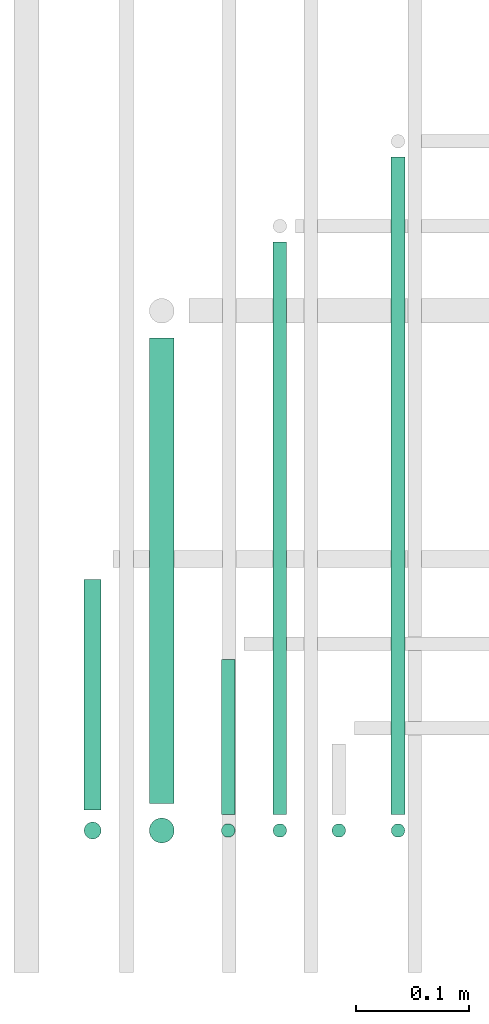
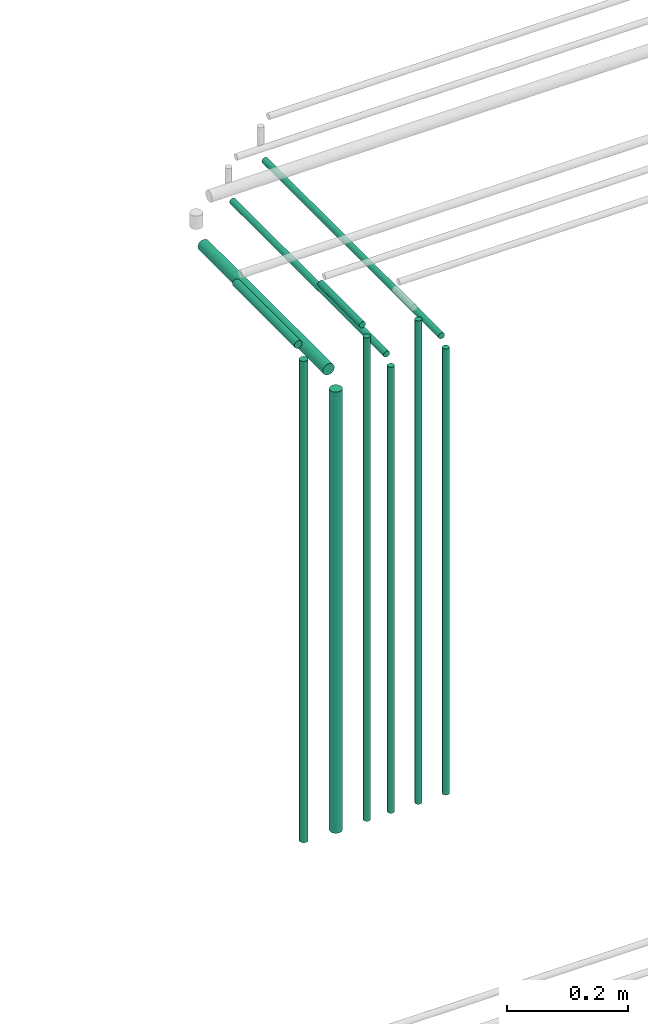
# One storey, part 125 of 331: 11 flow segments.
"""IFC2X3 building model written with IfcOpenShell, lengths in millimetres."""

from ifc_helpers import new_model, entity, si_unit, converted_unit, derived_unit, direction, frame, frame_2d, origin, origin_2d_with_axis, place, context, subcontext, project, spatial, circle, extrude, type_object, element, save


model = new_model("IFC2X3")

# Units and contexts
model_context = context("Model", 3, precision=0.01, world=origin(), true_north=direction((6.12303176911189e-17, 1.0)))
body_context = subcontext(model_context, "Body", "Model", "MODEL_VIEW")
ifc_project = project(units=[si_unit("LENGTHUNIT", "METRE", prefix="MILLI"), si_unit("AREAUNIT", "SQUARE_METRE"), si_unit("VOLUMEUNIT", "CUBIC_METRE"), converted_unit("PLANEANGLEUNIT", "DEGREE", entity("IfcRatioMeasure", 0.0174532925199433), si_unit("PLANEANGLEUNIT", "RADIAN"), dimensions=[0, 0, 0, 0, 0, 0, 0]), si_unit("MASSUNIT", "GRAM", prefix="KILO"), derived_unit("MASSDENSITYUNIT", [(si_unit("MASSUNIT", "GRAM", prefix="KILO"), 1), (si_unit("LENGTHUNIT", "METRE"), -3)]), derived_unit("MOMENTOFINERTIAUNIT", [(si_unit("LENGTHUNIT", "METRE"), 4)]), si_unit("TIMEUNIT", "SECOND"), si_unit("FREQUENCYUNIT", "HERTZ"), si_unit("THERMODYNAMICTEMPERATUREUNIT", "DEGREE_CELSIUS"), derived_unit("THERMALTRANSMITTANCEUNIT", [(si_unit("MASSUNIT", "GRAM", prefix="KILO"), 1), (si_unit("THERMODYNAMICTEMPERATUREUNIT", "KELVIN"), -1), (si_unit("TIMEUNIT", "SECOND"), -3)]), derived_unit("VOLUMETRICFLOWRATEUNIT", [(si_unit("LENGTHUNIT", "METRE"), 3), (si_unit("TIMEUNIT", "SECOND"), -1)]), derived_unit("MASSFLOWRATEUNIT", [(si_unit("MASSUNIT", "GRAM", prefix="KILO"), 1), (si_unit("TIMEUNIT", "SECOND"), -1)]), derived_unit("ROTATIONALFREQUENCYUNIT", [(si_unit("TIMEUNIT", "SECOND"), -1)]), si_unit("ELECTRICCURRENTUNIT", "AMPERE"), si_unit("ELECTRICVOLTAGEUNIT", "VOLT"), si_unit("POWERUNIT", "WATT"), si_unit("FORCEUNIT", "NEWTON", prefix="KILO"), si_unit("ILLUMINANCEUNIT", "LUX"), si_unit("LUMINOUSFLUXUNIT", "LUMEN"), si_unit("LUMINOUSINTENSITYUNIT", "CANDELA"), derived_unit("USERDEFINED", [(si_unit("MASSUNIT", "GRAM", prefix="KILO"), -1), (si_unit("LENGTHUNIT", "METRE"), -2), (si_unit("TIMEUNIT", "SECOND"), 3), (si_unit("LUMINOUSFLUXUNIT", "LUMEN"), 1)]), derived_unit("LINEARVELOCITYUNIT", [(si_unit("LENGTHUNIT", "METRE"), 1), (si_unit("TIMEUNIT", "SECOND"), -1)]), si_unit("PRESSUREUNIT", "PASCAL"), derived_unit("USERDEFINED", [(si_unit("LENGTHUNIT", "METRE"), -2), (si_unit("MASSUNIT", "GRAM", prefix="KILO"), 1), (si_unit("TIMEUNIT", "SECOND"), -2)]), derived_unit("LINEARFORCEUNIT", [(si_unit("MASSUNIT", "GRAM", prefix="KILO"), 1), (si_unit("LENGTHUNIT", "METRE"), 1), (si_unit("TIMEUNIT", "SECOND"), -2), (si_unit("LENGTHUNIT", "METRE"), -1)]), derived_unit("PLANARFORCEUNIT", [(si_unit("MASSUNIT", "GRAM", prefix="KILO"), 1), (si_unit("LENGTHUNIT", "METRE"), 1), (si_unit("TIMEUNIT", "SECOND"), -2), (si_unit("LENGTHUNIT", "METRE"), -2)])], contexts=[model_context])

# Site, building, storey
site_placement = place(None, frame((0.0, -0.00077364408347762, 0.0)))
site = spatial("IfcSite", under=ifc_project, at=site_placement, CompositionType="ELEMENT")
building_placement = place(site_placement, origin())
building = spatial("IfcBuilding", under=site, at=building_placement, CompositionType="ELEMENT")
storey_placement = place(building_placement, origin())
storey = spatial("IfcBuildingStorey", under=building, at=storey_placement, CompositionType="ELEMENT", Elevation=0.0)

# Flow segments
pipe_segment_type = type_object("IfcPipeSegmentType", PredefinedType="NOTDEFINED")
flow_segment_1_placement = place(storey_placement, frame((18973.7737980249, 8079.62056382735, 14467.404727873)))
element("IfcFlowSegment", 1, at=flow_segment_1_placement, inside=storey, type_object=pipe_segment_type, context=body_context, shape_type="SweptSolid", body=[
    extrude(circle(Radius=6.0, at=frame_2d((2.16573425859679e-12, 0.0), x_axis=(1.0, 0.0))), frame((7.59527223591887, 0.0, 7.5952722359167), z_axis=(0.0, 1.0, 0.0), x_axis=(-1.0, 0.0, 0.0)), (0.0, 0.0, 1.0), 582.000000000014),
])
flow_segment_2_placement = place(storey_placement, frame((18973.7737980249, 8058.02529159144, 13564.0)))
element("IfcFlowSegment", 2, at=flow_segment_2_placement, inside=storey, type_object=pipe_segment_type, context=body_context, shape_type="SweptSolid", body=[
    extrude(circle(Radius=6.0, at=origin_2d_with_axis()), frame((7.5952722359167, 7.59527223591562, 0.0)), (0.0, 0.0, 1.0), 897.000000108925),
])
flow_segment_3_placement = place(storey_placement, frame((18921.4061109664, 8058.02529159144, 13564.0)))
element("IfcFlowSegment", 3, at=flow_segment_3_placement, inside=storey, type_object=pipe_segment_type, context=body_context, shape_type="SweptSolid", body=[
    extrude(circle(Radius=6.0, at=origin_2d_with_axis()), frame((7.5952722359167, 7.59527223591562, 0.0)), (0.0, 0.0, 1.0), 972.000000000011),
])
flow_segment_4_placement = place(storey_placement, frame((18869.2157915365, 8079.62056382735, 14467.404727873)))
element("IfcFlowSegment", 4, at=flow_segment_4_placement, inside=storey, type_object=pipe_segment_type, context=body_context, shape_type="SweptSolid", body=[
    extrude(circle(Radius=6.0, at=frame_2d((6.49720277579036e-12, 0.0), x_axis=(1.0, 0.0))), frame((7.5952722359232, 0.0, 7.5952722359167), z_axis=(0.0, 1.0, 0.0), x_axis=(-1.0, 0.0, 0.0)), (0.0, 0.0, 1.0), 507.000000000026),
])
flow_segment_5_placement = place(storey_placement, frame((18869.2157915365, 8058.02529159143, 13564.0)))
element("IfcFlowSegment", 5, at=flow_segment_5_placement, inside=storey, type_object=pipe_segment_type, context=body_context, shape_type="SweptSolid", body=[
    extrude(circle(Radius=6.0, at=frame_2d((0.0, 1.08286712929839e-12), x_axis=(1.0, 0.0))), frame((7.5952722359167, 7.59527223591454, 0.0)), (0.0, 0.0, 1.0), 897.000000108945),
])
flow_segment_6_placement = place(storey_placement, frame((18823.455858175, 8079.62056382735, 14542.404728374)))
element("IfcFlowSegment", 6, at=flow_segment_6_placement, inside=storey, type_object=pipe_segment_type, context=body_context, shape_type="SweptSolid", body=[
    extrude(circle(Radius=6.0, at=frame_2d((-2.16573425859679e-12, 0.0), x_axis=(1.0, 0.0))), frame((7.59527223591887, 0.0, 7.5952722359167), z_axis=(0.0, 1.0, 0.0), x_axis=(-1.0, 0.0, 0.0)), (0.0, 0.0, 1.0), 137.389380012772),
])
flow_segment_7_placement = place(storey_placement, frame((18823.455858175, 8058.02529159143, 13564.0)))
element("IfcFlowSegment", 7, at=flow_segment_7_placement, inside=storey, type_object=pipe_segment_type, context=body_context, shape_type="SweptSolid", body=[
    extrude(circle(Radius=6.0, at=origin_2d_with_axis()), frame((7.5952722359167, 7.59527223591562, 0.0)), (0.0, 0.0, 1.0), 972.000000000013),
])
flow_segment_8_placement = place(storey_placement, frame((18759.6577850481, 8089.62056382735, 14462.404727873)))
element("IfcFlowSegment", 8, at=flow_segment_8_placement, inside=storey, type_object=pipe_segment_type, context=body_context, shape_type="SweptSolid", body=[
    extrude(circle(Radius=11.0, at=frame_2d((6.49720277579036e-12, 0.0), x_axis=(1.0, 0.0))), frame((12.5952722359199, 0.0, 12.5952722359156), z_axis=(0.0, 1.0, 0.0), x_axis=(-1.0, 0.0, 0.0)), (0.0, 0.0, 1.0), 412.000000000006),
])
flow_segment_9_placement = place(storey_placement, frame((18759.6577850481, 8053.02529159143, 13564.0)))
element("IfcFlowSegment", 9, at=flow_segment_9_placement, inside=storey, type_object=pipe_segment_type, context=body_context, shape_type="SweptSolid", body=[
    extrude(circle(Radius=11.0, at=origin_2d_with_axis()), frame((12.5952722359156, 12.5952722359156, 0.0)), (0.0, 0.0, 1.0), 887.000000108945),
])
flow_segment_10_placement = place(storey_placement, frame((18701.955858175, 8083.62055710965, 14540.902999856)))
element("IfcFlowSegment", 10, at=flow_segment_10_placement, inside=storey, type_object=pipe_segment_type, context=body_context, shape_type="SweptSolid", body=[
    extrude(circle(Radius=7.5, at=frame_2d((0.0, 2.16573425859679e-12), x_axis=(1.0, 0.0))), frame((9.09527223591636, 0.0, 9.09527223591419), z_axis=(0.0, 1.0, 0.0), x_axis=(-1.0, 0.0, 0.0)), (0.0, 0.0, 1.0), 204.389386739668),
])
flow_segment_11_placement = place(storey_placement, frame((18701.955858175, 8056.52529159143, 13564.0)))
element("IfcFlowSegment", 11, at=flow_segment_11_placement, inside=storey, type_object=pipe_segment_type, context=body_context, shape_type="SweptSolid", body=[
    extrude(circle(Radius=7.5, at=origin_2d_with_axis()), frame((9.09527223591636, 9.09527223591636, 0.0)), (0.0, 0.0, 1.0), 967.982720977144),
])

save(model, "model.ifc")
